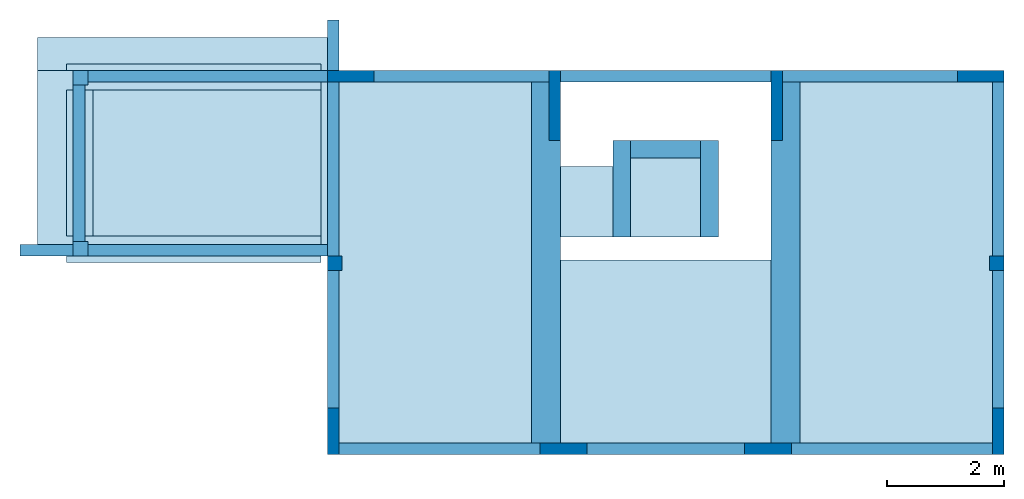
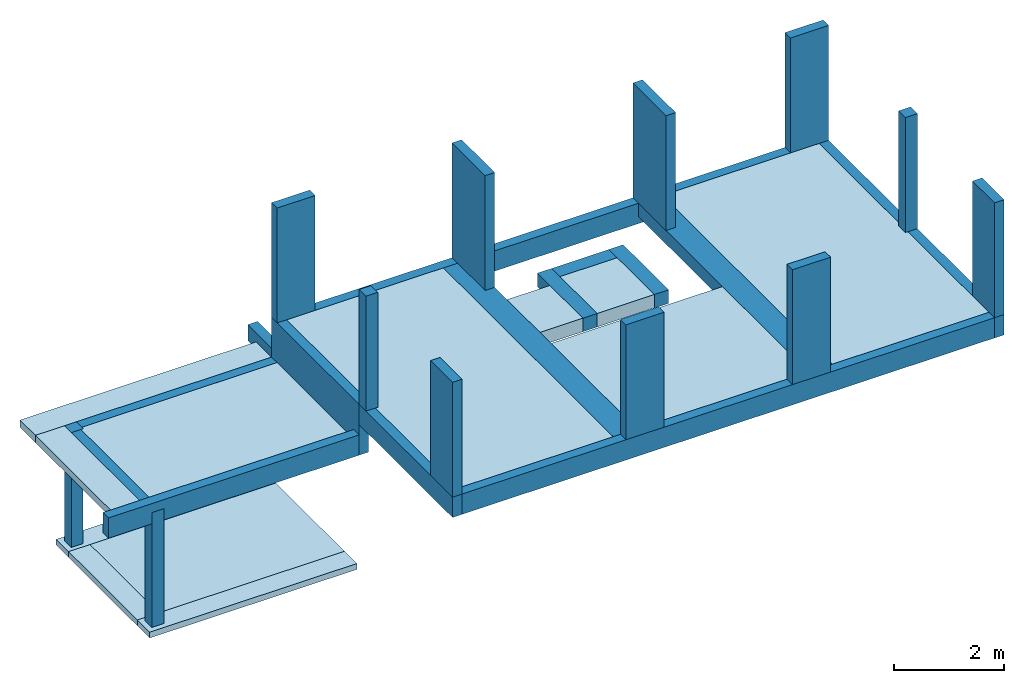
# One storey: 14 beams, 12 columns, 12 slabs.
"""IFC4 building model written with IfcOpenShell, lengths in metres."""

from ifc_helpers import new_model, entity, si_unit, converted_unit, direction, frame, frame_2d, origin_with_axes, origin_2d_with_axis, place, context, subcontext, project, spatial, polyline, rectangle, outline, extrude, element, save


model = new_model("IFC4")

# Units and contexts
model_context = context("Model", 3, precision=1e-05, world=origin_with_axes(), true_north=direction((6.12323399573677e-17, 1.0)))
body_context = subcontext(model_context, "Body", "Model", "MODEL_VIEW")
ifc_project = project(units=[si_unit("LENGTHUNIT", "METRE"), si_unit("AREAUNIT", "SQUARE_METRE"), si_unit("VOLUMEUNIT", "CUBIC_METRE"), converted_unit("PLANEANGLEUNIT", "DEGREE", entity("IfcPlaneAngleMeasure", 0.017453292519943295), si_unit("PLANEANGLEUNIT", "RADIAN"), dimensions=[0, 0, 0, 0, 0, 0, 0])], contexts=[model_context])

# Site, building, storey
site = spatial("IfcSite", under=ifc_project, CompositionType="COMPLEX")
building = spatial("IfcBuilding", under=site, Name="Italian House", CompositionType="COMPLEX")
storey_placement = place(None, frame((0.0, 0.0, 3.09999990463257), z_axis=(0.0, 0.0, 1.0), x_axis=(1.0, 0.0, 0.0)))
storey = spatial("IfcBuildingStorey", under=building, at=storey_placement, Name="Piano primo")

# Columns
column_1_placement = place(storey_placement, frame((0.0, 0.0, -3.09999990463257), z_axis=(0.0, 0.0, 1.0), x_axis=(1.0, 0.0, 0.0)))
element("IfcColumn", 1, at=column_1_placement, inside=storey, Name="P011_1", PredefinedType="COLUMN", context=body_context, shape_type="SweptSolid", body=[
    extrude(rectangle(XDim=0.25, YDim=0.25, at=frame_2d((2.00577401909818e-18, 3.46944695195361e-18), x_axis=(1.0, 0.0))), frame((0.125, -3.055, 0.13), z_axis=(0.0, 0.0, 1.0), x_axis=(1.0, 0.0, 0.0)), (0.0, 0.0, 1.0), 2.55),
])
column_2_placement = place(storey_placement, frame((0.0, 0.0, -3.09999990463257), z_axis=(0.0, 0.0, 1.0), x_axis=(1.0, 0.0, 0.0)))
element("IfcColumn", 2, at=column_2_placement, inside=storey, Name="P012_1", PredefinedType="COLUMN", context=body_context, shape_type="SweptSolid", body=[
    extrude(rectangle(XDim=0.25, YDim=0.25, at=frame_2d((2.00577401909818e-18, 3.46944695195361e-18), x_axis=(1.0, 0.0))), frame((0.125, -0.125, 0.13), z_axis=(0.0, 0.0, 1.0), x_axis=(1.0, 0.0, 0.0)), (0.0, 0.0, 1.0), 2.55),
])
column_3_placement = place(storey_placement, frame((0.0, 0.0, -3.09999990463257), z_axis=(0.0, 0.0, 1.0), x_axis=(1.0, 0.0, 0.0)))
element("IfcColumn", 3, at=column_3_placement, inside=storey, Name="P006_2", PredefinedType="COLUMN", context=body_context, shape_type="SweptSolid", body=[
    extrude(rectangle(XDim=0.8, YDim=0.2, at=frame_2d((1.32272665043234e-17, 3.03576608295941e-18), x_axis=(1.0, 0.0))), frame((15.53, -0.0999999999999959, 3.56), z_axis=(0.0, 0.0, 1.0), x_axis=(1.0, 0.0, 0.0)), (0.0, 0.0, 1.0), 2.55),
])
column_4_placement = place(storey_placement, frame((0.0, 0.0, -3.09999990463257), z_axis=(0.0, 0.0, 1.0), x_axis=(1.0, 0.0, 0.0)))
element("IfcColumn", 4, at=column_4_placement, inside=storey, Name="P007_2", PredefinedType="COLUMN", context=body_context, shape_type="SweptSolid", body=[
    extrude(rectangle(XDim=0.25, YDim=0.25, at=frame_2d((2.00577401909818e-18, 3.46944695195361e-18), x_axis=(1.0, 0.0))), frame((15.805, -3.305, 3.56), z_axis=(0.0, 0.0, 1.0), x_axis=(1.0, 0.0, 0.0)), (0.0, 0.0, 1.0), 2.55),
])
column_5_placement = place(storey_placement, frame((0.0, 0.0, -3.09999990463257), z_axis=(0.0, 0.0, 1.0), x_axis=(1.0, 0.0, 0.0)))
element("IfcColumn", 5, at=column_5_placement, inside=storey, Name="P008_2", PredefinedType="COLUMN", context=body_context, shape_type="SweptSolid", body=[
    extrude(rectangle(XDim=0.2, YDim=0.8, at=frame_2d((3.30681662608084e-18, 1.21430643318376e-17), x_axis=(1.0, 0.0))), frame((15.83, -6.18, 3.56), z_axis=(0.0, 0.0, 1.0), x_axis=(1.0, 0.0, 0.0)), (0.0, 0.0, 1.0), 2.55),
])
column_6_placement = place(storey_placement, frame((0.0, 0.0, -3.09999990463257), z_axis=(0.0, 0.0, 1.0), x_axis=(1.0, 0.0, 0.0)))
element("IfcColumn", 6, at=column_6_placement, inside=storey, Name="P003_2", PredefinedType="COLUMN", context=body_context, shape_type="SweptSolid", body=[
    extrude(rectangle(XDim=0.8, YDim=0.2, at=frame_2d((1.32272665043234e-17, 3.03576608295941e-18), x_axis=(1.0, 0.0))), frame((4.75, -0.0999999999999982, 3.56), z_axis=(0.0, 0.0, 1.0), x_axis=(1.0, 0.0, 0.0)), (0.0, 0.0, 1.0), 2.55),
])
column_7_placement = place(storey_placement, frame((0.0, 0.0, -3.09999990463257), z_axis=(0.0, 0.0, 1.0), x_axis=(1.0, 0.0, 0.0)))
element("IfcColumn", 7, at=column_7_placement, inside=storey, Name="P002_2", PredefinedType="COLUMN", context=body_context, shape_type="SweptSolid", body=[
    extrude(rectangle(XDim=0.25, YDim=0.25, at=frame_2d((2.00577401909818e-18, 3.46944695195361e-18), x_axis=(1.0, 0.0))), frame((4.475, -3.305, 3.56), z_axis=(0.0, 0.0, 1.0), x_axis=(1.0, 0.0, 0.0)), (0.0, 0.0, 1.0), 2.55),
])
column_8_placement = place(storey_placement, frame((0.0, 0.0, -3.09999990463257), z_axis=(0.0, 0.0, 1.0), x_axis=(1.0, 0.0, 0.0)))
element("IfcColumn", 8, at=column_8_placement, inside=storey, Name="P001_2", PredefinedType="COLUMN", context=body_context, shape_type="SweptSolid", body=[
    extrude(rectangle(XDim=0.2, YDim=0.8, at=frame_2d((3.30681662608084e-18, 1.21430643318376e-17), x_axis=(1.0, 0.0))), frame((4.45, -6.18, 3.56), z_axis=(0.0, 0.0, 1.0), x_axis=(1.0, 0.0, 0.0)), (0.0, 0.0, 1.0), 2.55),
])
column_9_placement = place(storey_placement, frame((0.0, 0.0, -3.09999990463257), z_axis=(0.0, 0.0, 1.0), x_axis=(1.0, 0.0, 0.0)))
element("IfcColumn", 9, at=column_9_placement, inside=storey, Name="P004_2", PredefinedType="COLUMN", context=body_context, shape_type="SweptSolid", body=[
    extrude(rectangle(XDim=0.2, YDim=1.2, at=frame_2d((3.30681662608079e-18, -2.42861286636753e-17), x_axis=(1.0, 0.0))), frame((8.24, -0.599999999999998, 3.56), z_axis=(0.0, 0.0, 1.0), x_axis=(1.0, 0.0, 0.0)), (0.0, 0.0, 1.0), 2.55),
])
column_10_placement = place(storey_placement, frame((0.0, 0.0, -3.09999990463257), z_axis=(0.0, 0.0, 1.0), x_axis=(1.0, 0.0, 0.0)))
element("IfcColumn", 10, at=column_10_placement, inside=storey, Name="P005_2", PredefinedType="COLUMN", context=body_context, shape_type="SweptSolid", body=[
    extrude(rectangle(XDim=0.2, YDim=1.2, at=frame_2d((3.30681662608079e-18, -2.42861286636753e-17), x_axis=(1.0, 0.0))), frame((12.04, -0.599999999999997, 3.56), z_axis=(0.0, 0.0, 1.0), x_axis=(1.0, 0.0, 0.0)), (0.0, 0.0, 1.0), 2.55),
])
column_11_placement = place(storey_placement, frame((0.0, 0.0, -3.09999990463257), z_axis=(0.0, 0.0, 1.0), x_axis=(1.0, 0.0, 0.0)))
element("IfcColumn", 11, at=column_11_placement, inside=storey, Name="P010_2", PredefinedType="COLUMN", context=body_context, shape_type="SweptSolid", body=[
    extrude(rectangle(XDim=0.8, YDim=0.2, at=frame_2d((1.32272665043234e-17, 3.03576608295941e-18), x_axis=(1.0, 0.0))), frame((8.39000001192093, -6.48000000596046, 3.56), z_axis=(0.0, 0.0, 1.0), x_axis=(0.999999999999993, -1.19209275e-07, 0.0)), (0.0, 0.0, 1.0), 2.55),
])
column_12_placement = place(storey_placement, frame((0.0, 0.0, -3.09999990463257), z_axis=(0.0, 0.0, 1.0), x_axis=(1.0, 0.0, 0.0)))
element("IfcColumn", 12, at=column_12_placement, inside=storey, Name="P009_2", PredefinedType="COLUMN", context=body_context, shape_type="SweptSolid", body=[
    extrude(rectangle(XDim=0.8, YDim=0.2, at=frame_2d((1.32272665043234e-17, 3.03576608295941e-18), x_axis=(1.0, 0.0))), frame((11.8900000119209, -6.47999999403953, 3.56), z_axis=(0.0, 0.0, 1.0), x_axis=(0.999999999999993, -1.19209275e-07, 0.0)), (0.0, 0.0, 1.0), 2.55),
])

# Beams
beam_1_placement = place(storey_placement, frame((0.0, 0.0, -3.09999990463257), z_axis=(0.0, 0.0, 1.0), x_axis=(1.0, 0.0, 0.0)))
element("IfcBeam", 13, at=beam_1_placement, inside=storey, Name="TR105", PredefinedType="BEAM", context=body_context, shape_type="SweptSolid", body=[
    extrude(rectangle(XDim=0.5, YDim=0.3, at=frame_2d((1.95156391047391e-18, -1.30104260698253e-17), x_axis=(0.0, 1.0))), frame((12.19, -6.58, 3.41), z_axis=(2.22044604925031e-16, 1.0, 0.0), x_axis=(0.0, 0.0, -1.0)), (0.0, 0.0, 1.0), 6.58),
])
beam_2_placement = place(storey_placement, frame((0.0, 0.0, -3.09999990463257), z_axis=(0.0, 0.0, 1.0), x_axis=(1.0, 0.0, 0.0)))
element("IfcBeam", 14, at=beam_2_placement, inside=storey, Name="TR106", PredefinedType="BEAM", context=body_context, shape_type="SweptSolid", body=[
    extrude(rectangle(XDim=0.5, YDim=0.3, at=frame_2d((1.95156391047391e-18, -1.30104260698253e-17), x_axis=(0.0, 1.0))), frame((8.09000039219856, -6.58000001490115, 3.41), z_axis=(-5.96046447753906e-08, 0.999999999999998, 0.0), x_axis=(0.0, 0.0, -1.0)), (0.0, 0.0, 1.0), 6.58),
])
beam_3_placement = place(storey_placement, frame((0.0, 0.0, -3.09999990463257), z_axis=(0.0, 0.0, 1.0), x_axis=(1.0, 0.0, 0.0)))
element("IfcBeam", 15, at=beam_3_placement, inside=storey, Name="TR111", PredefinedType="BEAM", context=body_context, shape_type="SweptSolid", body=[
    extrude(rectangle(XDim=0.3, YDim=0.3, at=frame_2d((1.95156391047391e-18, 4.62592926927142e-18), x_axis=(0.0, 1.0))), frame((10.89, -2.85, 3.41), z_axis=(2.22044604925031e-16, 1.0, 0.0), x_axis=(0.0, 0.0, -1.0)), (0.0, 0.0, 1.0), 1.65),
])
beam_4_placement = place(storey_placement, frame((0.0, 0.0, -3.09999990463257), z_axis=(0.0, 0.0, 1.0), x_axis=(1.0, 0.0, 0.0)))
element("IfcBeam", 16, at=beam_4_placement, inside=storey, Name="TR112", PredefinedType="BEAM", context=body_context, shape_type="SweptSolid", body=[
    extrude(rectangle(XDim=0.3, YDim=0.3, at=frame_2d((1.95156391047391e-18, 4.62592926927142e-18), x_axis=(0.0, 1.0))), frame((9.39000016987324, -2.85, 3.41), z_axis=(2.22044604925031e-16, 1.0, 0.0), x_axis=(0.0, 0.0, -1.0)), (0.0, 0.0, 1.0), 1.65),
])
beam_5_placement = place(storey_placement, frame((0.0, 0.0, -3.09999990463257), z_axis=(0.0, 0.0, 1.0), x_axis=(1.0, 0.0, 0.0)))
element("IfcBeam", 17, at=beam_5_placement, inside=storey, Name="TR113", PredefinedType="BEAM", context=body_context, shape_type="SweptSolid", body=[
    extrude(rectangle(XDim=0.3, YDim=0.3, at=frame_2d((1.95156391047391e-18, 4.62592926927142e-18), x_axis=(0.0, 1.0))), frame((10.7400001698732, -1.35, 3.41), z_axis=(-1.0, 0.0, 0.0), x_axis=(0.0, 0.0, -1.0)), (0.0, 0.0, 1.0), 1.2),
])
beam_6_placement = place(storey_placement, frame((0.0, 0.0, -3.09999990463257), z_axis=(0.0, 0.0, 1.0), x_axis=(1.0, 0.0, 0.0)))
element("IfcBeam", 18, at=beam_6_placement, inside=storey, Name="TR101", PredefinedType="BEAM", context=body_context, shape_type="SweptSolid", body=[
    extrude(rectangle(XDim=0.2, YDim=0.45, at=frame_2d((-3.68628738645069e-18, -1.34922937020427e-18), x_axis=(0.0, 1.0))), frame((4.35, -6.48, 3.335), z_axis=(1.0, 0.0, 0.0), x_axis=(0.0, 0.0, -1.0)), (0.0, 0.0, 1.0), 11.58),
])
beam_7_placement = place(storey_placement, frame((0.0, 0.0, -3.09999990463257), z_axis=(0.0, 0.0, 1.0), x_axis=(1.0, 0.0, 0.0)))
element("IfcBeam", 19, at=beam_7_placement, inside=storey, Name="TR102", PredefinedType="BEAM", context=body_context, shape_type="SweptSolid", body=[
    extrude(rectangle(XDim=0.2, YDim=0.45, at=frame_2d((-3.68628738645069e-18, -1.34922937020427e-18), x_axis=(0.0, 1.0))), frame((4.35, -0.0999999999999964, 3.335), z_axis=(1.0, 0.0, 0.0), x_axis=(0.0, 0.0, -1.0)), (0.0, 0.0, 1.0), 11.58),
])
beam_8_placement = place(storey_placement, frame((0.0, 0.0, -3.09999990463257), z_axis=(0.0, 0.0, 1.0), x_axis=(1.0, 0.0, 0.0)))
element("IfcBeam", 20, at=beam_8_placement, inside=storey, Name="TR104", PredefinedType="BEAM", context=body_context, shape_type="SweptSolid", body=[
    extrude(rectangle(XDim=0.2, YDim=0.45, at=frame_2d((-3.68628738645069e-18, -1.34922937020427e-18), x_axis=(0.0, 1.0))), frame((15.83, -6.58, 3.335), z_axis=(2.22044604925031e-16, 1.0, 0.0), x_axis=(0.0, 0.0, -1.0)), (0.0, 0.0, 1.0), 6.58),
])
beam_9_placement = place(storey_placement, frame((0.0, 0.0, -3.09999990463257), z_axis=(0.0, 0.0, 1.0), x_axis=(1.0, 0.0, 0.0)))
element("IfcBeam", 21, at=beam_9_placement, inside=storey, Name="TR107_1", PredefinedType="BEAM", context=body_context, shape_type="SweptSolid", body=[
    extrude(rectangle(XDim=0.2, YDim=0.45, at=frame_2d((-3.68628738645069e-18, -1.34922937020427e-18), x_axis=(0.0, 1.0))), frame((4.45, -6.58, 3.335), z_axis=(2.22044604925031e-16, 1.0, 0.0), x_axis=(0.0, 0.0, -1.0)), (0.0, 0.0, 1.0), 3.4),
])
beam_10_placement = place(storey_placement, frame((0.0, 0.0, -3.09999990463257), z_axis=(0.0, 0.0, 1.0), x_axis=(1.0, 0.0, 0.0)))
element("IfcBeam", 22, at=beam_10_placement, inside=storey, Name="TR107_2", PredefinedType="BEAM", context=body_context, shape_type="SweptSolid", body=[
    extrude(rectangle(XDim=0.2, YDim=1.13, at=frame_2d((1.66967134562768e-17, -1.90359036301879e-18), x_axis=(0.0, 1.0))), frame((4.45, -3.18, 2.995), z_axis=(2.22044604925031e-16, 1.0, 0.0), x_axis=(0.0, 0.0, -1.0)), (0.0, 0.0, 1.0), 3.18),
])
beam_11_placement = place(storey_placement, frame((0.0, 0.0, -3.09999990463257), z_axis=(0.0, 0.0, 1.0), x_axis=(1.0, 0.0, 0.0)))
element("IfcBeam", 23, at=beam_11_placement, inside=storey, Name="TR108", PredefinedType="BEAM", context=body_context, shape_type="SweptSolid", body=[
    extrude(rectangle(XDim=0.2, YDim=0.35, at=frame_2d((3.90312782094782e-18, -4.58462632936761e-18), x_axis=(0.0, 1.0))), frame((0.1, -3.18, 2.505), z_axis=(2.22044604925031e-16, 1.0, 0.0), x_axis=(0.0, 0.0, -1.0)), (0.0, 0.0, 1.0), 3.18),
])
beam_12_placement = place(storey_placement, frame((0.0, 0.0, -3.09999990463257), z_axis=(0.0, 0.0, 1.0), x_axis=(1.0, 0.0, 0.0)))
element("IfcBeam", 24, at=beam_12_placement, inside=storey, Name="TR103", PredefinedType="BEAM", context=body_context, shape_type="SweptSolid", body=[
    extrude(rectangle(XDim=0.2, YDim=0.45, at=frame_2d((-3.68628738645069e-18, -1.34922937020427e-18), x_axis=(0.0, 1.0))), frame((-0.910000000000002, -3.08, 2.655), z_axis=(1.0, 0.0, 0.0), x_axis=(0.0, 0.0, -1.0)), (0.0, 0.0, 1.0), 5.26),
])
beam_13_placement = place(storey_placement, frame((0.0, 0.0, -3.09999990463257), z_axis=(0.0, 0.0, 1.0), x_axis=(1.0, 0.0, 0.0)))
element("IfcBeam", 25, at=beam_13_placement, inside=storey, Name="TR109", PredefinedType="BEAM", context=body_context, shape_type="SweptSolid", body=[
    extrude(rectangle(XDim=0.2, YDim=0.35, at=frame_2d((3.90312782094782e-18, -4.58462632936761e-18), x_axis=(0.0, 1.0))), frame((0.0, -0.1, 2.505), z_axis=(1.0, 0.0, 0.0), x_axis=(0.0, 0.0, -1.0)), (0.0, 0.0, 1.0), 4.35),
])
beam_14_placement = place(storey_placement, frame((0.0, 0.0, -3.09999990463257), z_axis=(0.0, 0.0, 1.0), x_axis=(1.0, 0.0, 0.0)))
element("IfcBeam", 26, at=beam_14_placement, inside=storey, Name="TR110", PredefinedType="BEAM", context=body_context, shape_type="SweptSolid", body=[
    extrude(rectangle(XDim=0.2, YDim=0.36, at=frame_2d((5.20417042793042e-18, 1.66244333114451e-18), x_axis=(0.0, 1.0))), frame((4.45, 1.819e-15, 2.7), z_axis=(2.22044604925031e-16, 1.0, 0.0), x_axis=(0.0, 0.0, -1.0)), (0.0, 0.0, 1.0), 0.86),
])

# Slabs
slab_1_placement = place(storey_placement, frame((0.0, 0.0, -3.09999990463257), z_axis=(0.0, 0.0, 1.0), x_axis=(1.0, 0.0, 0.0)))
element("IfcSlab", 27, at=slab_1_placement, inside=storey, Name="TR001_2", PredefinedType="FLOOR", context=body_context, shape_type="SweptSolid", body=[
    extrude(rectangle(XDim=4.35, YDim=0.45, at=frame_2d((-4.54747350886464e-13, 0.0), x_axis=(1.0, 0.0))), frame((2.065, -0.115, 0.13), z_axis=(0.0, 0.0, 1.0), x_axis=(1.0, 0.0, 0.0)), (0.0, 0.0, -1.0), 0.13),
])
slab_2_placement = place(storey_placement, frame((0.0, 0.0, -3.09999990463257), z_axis=(0.0, 0.0, 1.0), x_axis=(1.0, 0.0, 0.0)))
element("IfcSlab", 28, at=slab_2_placement, inside=storey, Name="TR008", PredefinedType="FLOOR", context=body_context, shape_type="SweptSolid", body=[
    extrude(rectangle(XDim=0.45, YDim=2.5, at=origin_2d_with_axis()), frame((0.115, -1.59, 0.13), z_axis=(0.0, 0.0, 1.0), x_axis=(1.0, 0.0, 0.0)), (0.0, 0.0, -1.0), 0.13),
])
slab_3_placement = place(storey_placement, frame((0.0, 0.0, -3.09999990463257), z_axis=(0.0, 0.0, 1.0), x_axis=(1.0, 0.0, 0.0)))
element("IfcSlab", 29, at=slab_3_placement, inside=storey, Name="TR009", PredefinedType="FLOOR", context=body_context, shape_type="SweptSolid", body=[
    extrude(rectangle(XDim=4.35, YDim=0.45, at=frame_2d((-4.54747350886464e-13, 0.0), x_axis=(1.0, 0.0))), frame((2.065, -3.065, 0.13), z_axis=(0.0, 0.0, 1.0), x_axis=(1.0, 0.0, 0.0)), (0.0, 0.0, -1.0), 0.13),
])
slab_4_placement = place(storey_placement, frame((0.0, 0.0, -3.09999990463257), z_axis=(0.0, 0.0, 1.0), x_axis=(1.0, 0.0, 0.0)))
element("IfcSlab", 30, at=slab_4_placement, inside=storey, Name="Solaio007", PredefinedType="FLOOR", context=body_context, shape_type="SweptSolid", body=[
    extrude(rectangle(XDim=3.9, YDim=2.5, at=origin_2d_with_axis()), frame((2.29, -1.59, 0.13), z_axis=(0.0, 0.0, 1.0), x_axis=(1.0, 0.0, 0.0)), (0.0, 0.0, -1.0), 0.18),
])
slab_5_placement = place(storey_placement, frame((0.0, 0.0, -3.09999990463257), z_axis=(0.0, 0.0, 1.0), x_axis=(1.0, 0.0, 0.0)))
element("IfcSlab", 31, at=slab_5_placement, inside=storey, Name="001", PredefinedType="FLOOR", context=body_context, shape_type="SweptSolid", body=[
    extrude(outline(polyline([(-0.153225806451613, 0.467741935483871), (-0.153225806451613, -0.582258064516129), (0.146774193548387, -0.582258064516129), (0.146774193548387, 0.617741935483871), (-0.0032258064516127, 0.617741935483871), (-0.153225806451613, 0.467741935483871)])), frame((8.34000016987324, -2.26774193548387, 3.41322580645161), z_axis=(-1.0, 0.0, 0.0), x_axis=(0.0, 0.0, 1.0)), (0.0, 0.0, -1.0), 0.9),
])
slab_6_placement = place(storey_placement, frame((0.0, 0.0, -3.09999990463257), z_axis=(0.0, 0.0, 1.0), x_axis=(1.0, 0.0, 0.0)))
element("IfcSlab", 32, at=slab_6_placement, inside=storey, Name="Solaio009", PredefinedType="FLOOR", context=body_context, shape_type="SweptSolid", body=[
    extrude(rectangle(XDim=3.59999980628491, YDim=3.12999999999999, at=frame_2d((0.0, -2.27373675443232e-13), x_axis=(1.0, 0.0))), frame((10.1400000968575, -4.815, 3.56), z_axis=(0.0, 0.0, 1.0), x_axis=(1.0, 0.0, 0.0)), (0.0, 0.0, -1.0), 0.3),
])
slab_7_placement = place(storey_placement, frame((0.0, 0.0, -3.09999990463257), z_axis=(0.0, 0.0, 1.0), x_axis=(1.0, 0.0, 0.0)))
element("IfcSlab", 33, at=slab_7_placement, inside=storey, Name="Solaio010", PredefinedType="FLOOR", context=body_context, shape_type="SweptSolid", body=[
    extrude(rectangle(XDim=1.19999983012676, YDim=1.35, at=frame_2d((0.0, 1.13686837721616e-13), x_axis=(1.0, 0.0))), frame((10.1400000849366, -2.175, 3.56), z_axis=(0.0, 0.0, 1.0), x_axis=(1.0, 0.0, 0.0)), (0.0, 0.0, -1.0), 0.3),
])
slab_8_placement = place(storey_placement, frame((0.0, 0.0, -3.09999990463257), z_axis=(0.0, 0.0, 1.0), x_axis=(1.0, 0.0, 0.0)))
element("IfcSlab", 34, at=slab_8_placement, inside=storey, Name="Solaio012", PredefinedType="FLOOR", context=body_context, shape_type="SweptSolid", body=[
    extrude(rectangle(XDim=4.15, YDim=2.78, at=origin_2d_with_axis()), frame((2.275, -1.59, 2.68), z_axis=(0.0, 0.0, 1.0), x_axis=(1.0, 0.0, 0.0)), (0.0, 0.0, -1.0), 0.25),
])
slab_9_placement = place(storey_placement, frame((0.0, 0.0, -3.09999990463257), z_axis=(0.0, 0.0, 1.0), x_axis=(1.0, 0.0, 0.0)))
element("IfcSlab", 35, at=slab_9_placement, inside=storey, Name="Solaio008", PredefinedType="FLOOR", context=body_context, shape_type="SweptSolid", body=[
    extrude(rectangle(XDim=3.29, YDim=6.18000000000001, at=origin_2d_with_axis()), frame((14.085, -3.29, 3.56), z_axis=(0.0, 0.0, 1.0), x_axis=(1.0, 0.0, 0.0)), (0.0, 0.0, -1.0), 0.3),
])
slab_10_placement = place(storey_placement, frame((0.0, 0.0, -3.09999990463257), z_axis=(0.0, 0.0, 1.0), x_axis=(1.0, 0.0, 0.0)))
element("IfcSlab", 36, at=slab_10_placement, inside=storey, Name="Solaio011", PredefinedType="FLOOR", context=body_context, shape_type="SweptSolid", body=[
    extrude(rectangle(XDim=3.29000001192093, YDim=6.18000000000001, at=frame_2d((2.27373675443232e-13, 0.0), x_axis=(1.0, 0.0))), frame((6.19500000596046, -3.29, 3.56), z_axis=(0.0, 0.0, 1.0), x_axis=(1.0, 0.0, 0.0)), (0.0, 0.0, -1.0), 0.3),
])
slab_11_placement = place(storey_placement, frame((0.0, 0.0, -3.09999990463257), z_axis=(0.0, 0.0, 1.0), x_axis=(1.0, 0.0, 0.0)))
element("IfcSlab", 37, at=slab_11_placement, inside=storey, Name="003", PredefinedType="FLOOR", context=body_context, shape_type="SweptSolid", body=[
    extrude(rectangle(XDim=4.96, YDim=0.559999999999998, at=origin_2d_with_axis()), frame((1.87, 0.280000000000001, 2.68), z_axis=(0.0, 0.0, 1.0), x_axis=(1.0, 0.0, 0.0)), (0.0, 0.0, -1.0), 0.16),
])
slab_12_placement = place(storey_placement, frame((0.0, 0.0, -3.09999990463257), z_axis=(0.0, 0.0, 1.0), x_axis=(1.0, 0.0, 0.0)))
element("IfcSlab", 38, at=slab_12_placement, inside=storey, Name="002", PredefinedType="FLOOR", context=body_context, shape_type="SweptSolid", body=[
    extrude(rectangle(XDim=0.61, YDim=3.18, at=frame_2d((0.0, 0.0), x_axis=(-1.0, 0.0))), frame((-0.305, -1.59, 2.68), z_axis=(0.0, 0.0, 1.0), x_axis=(1.0, 0.0, 0.0)), (0.0, 0.0, -1.0), 0.16),
])

save(model, "model.ifc")
